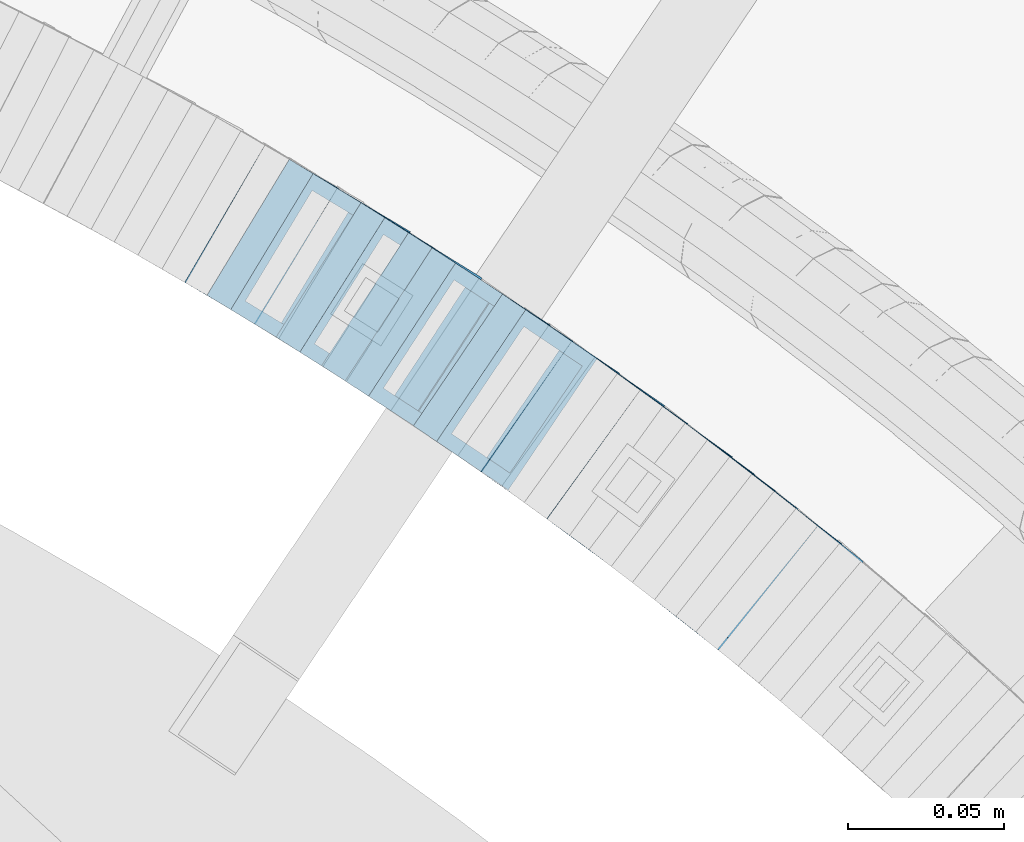
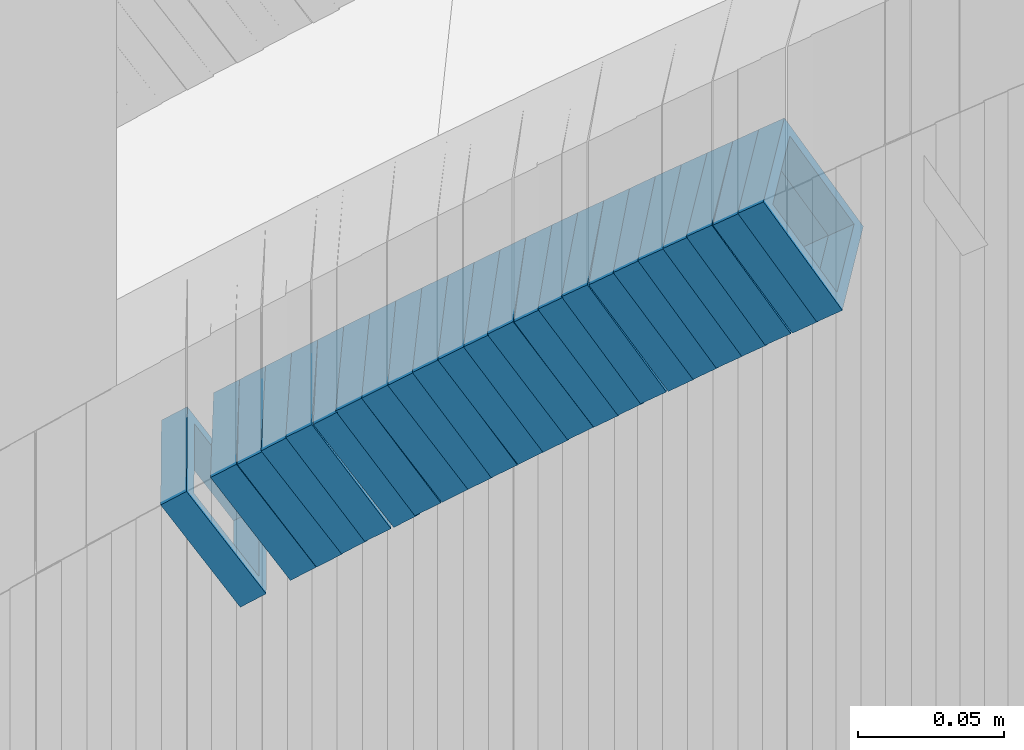
# One storey, part 751 of 975: 23 members.
"""IFC2X3 building model written with IfcOpenShell, lengths in millimetres."""

from ifc_helpers import new_model, si_unit, frame, origin_with_axes, place, context, subcontext, project, spatial, faceted_brep, material, type_object, element, save


model = new_model("IFC2X3")

# Units and contexts
model_context = context("Model", 3, precision=1e-05, world=origin_with_axes())
body_context = subcontext(model_context, "Body", "Model", "MODEL_VIEW")
ifc_project = project(units=[si_unit("LENGTHUNIT", "METRE", prefix="MILLI"), si_unit("AREAUNIT", "SQUARE_METRE"), si_unit("VOLUMEUNIT", "CUBIC_METRE"), si_unit("MASSUNIT", "GRAM", prefix="KILO"), si_unit("TIMEUNIT", "SECOND"), si_unit("PLANEANGLEUNIT", "RADIAN"), si_unit("SOLIDANGLEUNIT", "STERADIAN"), si_unit("THERMODYNAMICTEMPERATUREUNIT", "DEGREE_CELSIUS"), si_unit("LUMINOUSINTENSITYUNIT", "LUMEN")], contexts=[model_context])

# Site, building, storey
site_placement = place(None, origin_with_axes())
site = spatial("IfcSite", under=ifc_project, at=site_placement, CompositionType="ELEMENT")
building_placement = place(site_placement, origin_with_axes())
building = spatial("IfcBuilding", under=site, at=building_placement, Name="Undefined", CompositionType="ELEMENT")
storey_placement = place(building_placement, origin_with_axes())
storey = spatial("IfcBuildingStorey", under=building, at=storey_placement, Name="Undefined", CompositionType="ELEMENT", Elevation=0.0)

# Members
ifc_material = material()
member_type = type_object("IfcMemberType", Name="HSS2X2X.188_TUBES", PredefinedType="NOTDEFINED")
member_1_placement = place(storey_placement, frame((35608.852572287, 4493.42317874416, 1653.40910193398), z_axis=(0.617821551956294, 0.786318338803259, 5.58209194423397e-11), x_axis=(0.662206907099033, -0.520305427077882, 0.539225625080666)))
element("IfcMember", 1, at=member_1_placement, inside=storey, type_object=member_type, material=ifc_material, Name="WALL", ObjectType="HSS2X2X.188_TUBES", context=body_context, shape_type="Brep", body=[
    faceted_brep([(0.0, 20.6374999999753, -20.6375000000298), (0.0, -20.6375000000153, -20.6375000000153), (10.5744976239494, -20.6375000000207, -20.6375000000335), (10.5744976239657, 20.6375000000098, -20.637500000008), (0.0, -20.6374999999825, 20.6375000000335), (10.5744976239639, -20.6375000000244, 20.6374999999753), (0.0, 20.6375000000116, 20.6375000000189), (10.5744976239803, 20.6374999999989, 20.6374999999935), (0.0, 25.3999999999724, -25.4000000000342), (0.0, 25.400000000016, 25.4000000000196), (10.5744976239857, 25.4000000000051, 25.4000000000015), (10.5744976239675, 25.4000000000124, -25.4000000000051), (0.0, -25.399999999976, 25.4000000000378), (10.5744976239639, -25.4000000000287, 25.3999999999724), (0.0, -25.400000000016, -25.4000000000196), (10.5744976239494, -25.4000000000215, -25.4000000000378)], [[[0, 1, 2, 3]], [[1, 4, 5, 2]], [[4, 6, 7, 5]], [[6, 0, 3, 7]], [[8, 9, 10, 11]], [[9, 12, 13, 10]], [[12, 14, 15, 13]], [[14, 8, 11, 15]], [[13, 15, 11, 10], [5, 7, 3, 2]], [[14, 12, 9, 8], [6, 4, 1, 0]]]),
])
member_2_placement = place(storey_placement, frame((35602.0141708895, 4498.83895323166, 1647.66268788927), z_axis=(0.612397742431603, 0.790549811880742, -1.31450178741943e-10), x_axis=(0.664102681131935, -0.514445739102132, 0.542506415107726)))
element("IfcMember", 2, at=member_2_placement, inside=storey, type_object=member_type, material=ifc_material, Name="WALL", ObjectType="HSS2X2X.188_TUBES", context=body_context, shape_type="Brep", body=[
    faceted_brep([(0.0, 20.6374999999753, -20.6375000000298), (0.0, -20.6375000000153, -20.6375000000153), (10.6906501205649, -20.6374999999844, -20.637499999968), (10.690650120574, 20.6375000000098, -20.6374999999716), (0.0, -20.6374999999825, 20.6375000000335), (10.6906501205467, -20.6374999999844, 20.637500000008), (0.0, 20.6375000000116, 20.6375000000189), (10.6906501205558, 20.637500000008, 20.6375000000007), (0.0, 25.3999999999724, -25.4000000000342), (0.0, 25.400000000016, 25.4000000000196), (10.6906501205522, 25.4000000000087, 25.3999999999978), (10.6906501205813, 25.4000000000124, -25.3999999999651), (0.0, -25.399999999976, 25.4000000000378), (10.6906501205431, -25.3999999999833, 25.4000000000051), (0.0, -25.400000000016, -25.4000000000196), (10.6906501205704, -25.3999999999833, -25.3999999999614)], [[[0, 1, 2, 3]], [[1, 4, 5, 2]], [[4, 6, 7, 5]], [[6, 0, 3, 7]], [[8, 9, 10, 11]], [[9, 12, 13, 10]], [[12, 14, 15, 13]], [[14, 8, 11, 15]], [[13, 15, 11, 10], [5, 7, 3, 2]], [[14, 12, 9, 8], [6, 4, 1, 0]]]),
])
member_3_placement = place(storey_placement, frame((35594.752572287, 4504.42317874415, 1641.90910193393), z_axis=(0.617821551956294, 0.786318338803259, 5.58209194423397e-11), x_axis=(0.662206907099033, -0.520305427077882, 0.539225625080666)))
element("IfcMember", 3, at=member_3_placement, inside=storey, type_object=member_type, material=ifc_material, Name="WALL", ObjectType="HSS2X2X.188_TUBES", context=body_context, shape_type="Brep", body=[
    faceted_brep([(0.0, 20.6374999999753, -20.6375000000298), (0.0, -20.6375000000153, -20.6375000000153), (10.5744976239494, -20.6375000000207, -20.6375000000335), (10.5744976239657, 20.6375000000098, -20.637500000008), (0.0, -20.6374999999825, 20.6375000000335), (10.5744976239639, -20.6375000000244, 20.6374999999753), (0.0, 20.6375000000116, 20.6375000000189), (10.5744976239803, 20.6374999999989, 20.6374999999935), (0.0, 25.3999999999724, -25.4000000000342), (0.0, 25.400000000016, 25.4000000000196), (10.5744976239857, 25.4000000000051, 25.4000000000015), (10.5744976239675, 25.4000000000124, -25.4000000000051), (0.0, -25.399999999976, 25.4000000000378), (10.5744976239639, -25.4000000000287, 25.3999999999724), (0.0, -25.400000000016, -25.4000000000196), (10.5744976239494, -25.4000000000215, -25.4000000000378)], [[[0, 1, 2, 3]], [[1, 4, 5, 2]], [[4, 6, 7, 5]], [[6, 0, 3, 7]], [[8, 9, 10, 11]], [[9, 12, 13, 10]], [[12, 14, 15, 13]], [[14, 8, 11, 15]], [[13, 15, 11, 10], [5, 7, 3, 2]], [[14, 12, 9, 8], [6, 4, 1, 0]]]),
])
member_4_placement = place(storey_placement, frame((35588.0851947886, 4509.76105518458, 1636.1965843137), z_axis=(0.60536747118571, 0.795946119300935, -2.19542926060967e-11), x_axis=(0.670707309990836, -0.510115418993068, 0.538455163992679)))
element("IfcMember", 4, at=member_4_placement, inside=storey, type_object=member_type, material=ifc_material, Name="WALL", ObjectType="HSS2X2X.188_TUBES", context=body_context, shape_type="Brep", body=[
    faceted_brep([(0.0, 20.6374999999753, -20.6375000000298), (0.0, -20.6375000000153, -20.6375000000153), (10.5948100501191, -20.6375000000335, -20.6375000000844), (10.5948100501555, 20.6374999999971, -20.6375000000116), (0.0, -20.6374999999825, 20.6375000000335), (10.5948100501446, -20.6375000000098, 20.6374999999571), (0.0, 20.6375000000116, 20.6375000000189), (10.5948100501828, 20.6375000000189, 20.6375000000298), (0.0, 25.3999999999724, -25.4000000000342), (0.0, 25.400000000016, 25.4000000000196), (10.5948100501919, 25.4000000000251, 25.4000000000451), (10.5948100501591, 25.3999999999978, -25.4000000000051), (0.0, -25.399999999976, 25.4000000000378), (10.5948100501482, -25.4000000000106, 25.3999999999578), (0.0, -25.400000000016, -25.4000000000196), (10.5948100501118, -25.4000000000378, -25.400000000096)], [[[0, 1, 2, 3]], [[1, 4, 5, 2]], [[4, 6, 7, 5]], [[6, 0, 3, 7]], [[8, 9, 10, 11]], [[9, 12, 13, 10]], [[12, 14, 15, 13]], [[14, 8, 11, 15]], [[13, 15, 11, 10], [5, 7, 3, 2]], [[14, 12, 9, 8], [6, 4, 1, 0]]]),
])
member_5_placement = place(storey_placement, frame((35581.0078218624, 4515.18335922341, 1630.4415954991), z_axis=(0.599999999847897, 0.800000000114077, 6.1926584749017e-11), x_axis=(0.675855260383057, -0.506891445287378, 0.535052081303328)))
element("IfcMember", 5, at=member_5_placement, inside=storey, type_object=member_type, material=ifc_material, Name="WALL", ObjectType="HSS2X2X.188_TUBES", context=body_context, shape_type="Brep", body=[
    faceted_brep([(0.0, 20.6374999999753, -20.6375000000298), (0.0, -20.6375000000153, -20.6375000000153), (10.648004507897, -20.6374999999862, -20.637499999968), (10.6480045078188, 20.6374999999771, -20.6375000000808), (0.0, -20.6374999999825, 20.6375000000335), (10.6480045079406, -20.6374999999698, 20.6375000001062), (0.0, 20.6375000000116, 20.6375000000189), (10.6480045078679, 20.6374999999935, 20.6375000000007), (0.0, 25.3999999999724, -25.4000000000342), (0.0, 25.400000000016, 25.4000000000196), (10.6480045078661, 25.3999999999905, 25.4000000000015), (10.648004507806, 25.3999999999705, -25.4000000000997), (0.0, -25.399999999976, 25.4000000000378), (10.6480045079552, -25.3999999999633, 25.4000000001288), (0.0, -25.400000000016, -25.4000000000196), (10.6480045078988, -25.3999999999814, -25.3999999999651)], [[[0, 1, 2, 3]], [[1, 4, 5, 2]], [[4, 6, 7, 5]], [[6, 0, 3, 7]], [[8, 9, 10, 11]], [[9, 12, 13, 10]], [[12, 14, 15, 13]], [[14, 8, 11, 15]], [[13, 15, 11, 10], [5, 7, 3, 2]], [[14, 12, 9, 8], [6, 4, 1, 0]]]),
])
member_6_placement = place(storey_placement, frame((35574.2508798489, 4520.30696019008, 1624.79130712751), z_axis=(0.592817428552363, 0.805336883797435, 3.6648793866334e-10), x_axis=(0.675617177995574, -0.497329311996768, 0.544247171996436)))
element("IfcMember", 6, at=member_6_placement, inside=storey, type_object=member_type, material=ifc_material, Name="WALL", ObjectType="HSS2X2X.188_TUBES", context=body_context, shape_type="Brep", body=[
    faceted_brep([(0.0, 20.6374999999753, -20.6375000000298), (0.0, -20.6375000000153, -20.6375000000153), (10.6625512894789, -20.6374999999625, -20.6374999999389), (10.6625512893879, 20.6374999999789, -20.6375000000371), (0.0, -20.6374999999825, 20.6375000000335), (10.6625512894352, -20.6374999999989, 20.6375000000153), (0.0, 20.6375000000116, 20.6375000000189), (10.6625512893443, 20.6374999999443, 20.6374999999134), (0.0, 25.3999999999724, -25.4000000000342), (0.0, 25.400000000016, 25.4000000000196), (10.6625512893297, 25.3999999999342, 25.3999999998996), (10.6625512893916, 25.399999999976, -25.4000000000415), (0.0, -25.399999999976, 25.4000000000378), (10.6625512894389, -25.399999999996, 25.400000000016), (0.0, -25.400000000016, -25.4000000000196), (10.6625512894971, -25.3999999999523, -25.3999999999214)], [[[0, 1, 2, 3]], [[1, 4, 5, 2]], [[4, 6, 7, 5]], [[6, 0, 3, 7]], [[8, 9, 10, 11]], [[9, 12, 13, 10]], [[12, 14, 15, 13]], [[14, 8, 11, 15]], [[13, 15, 11, 10], [5, 7, 3, 2]], [[14, 12, 9, 8], [6, 4, 1, 0]]]),
])
member_7_placement = place(storey_placement, frame((35559.7147513933, 4530.90716585884, 1613.2825958355), z_axis=(0.592817428552363, 0.805336883797435, 3.6648793866334e-10), x_axis=(0.679063997791765, -0.499866553846968, 0.537592331835399)))
element("IfcMember", 7, at=member_7_placement, inside=storey, type_object=member_type, material=ifc_material, Name="WALL", ObjectType="HSS2X2X.188_TUBES", context=body_context, shape_type="Brep", body=[
    faceted_brep([(0.0, 20.6374999999753, -20.6375000000298), (0.0, -20.6375000000153, -20.6375000000153), (10.6004716875832, -20.6375000000153, -20.6375000000553), (10.6004716875814, 20.6374999999898, -20.6375000000444), (0.0, -20.6374999999825, 20.6375000000335), (10.6004716876068, -20.6375000000044, 20.6374999999862), (0.0, 20.6375000000116, 20.6375000000189), (10.6004716876032, 20.6374999999989, 20.6374999999971), (0.0, 25.3999999999724, -25.4000000000342), (0.0, 25.400000000016, 25.4000000000196), (10.600471687605, 25.4000000000015, 25.4000000000051), (10.6004716875814, 25.3999999999869, -25.4000000000487), (0.0, -25.399999999976, 25.4000000000378), (10.6004716876068, -25.4000000000015, 25.3999999999905), (0.0, -25.400000000016, -25.4000000000196), (10.6004716875814, -25.4000000000178, -25.4000000000669)], [[[0, 1, 2, 3]], [[1, 4, 5, 2]], [[4, 6, 7, 5]], [[6, 0, 3, 7]], [[8, 9, 10, 11]], [[9, 12, 13, 10]], [[12, 14, 15, 13]], [[14, 8, 11, 15]], [[13, 15, 11, 10], [5, 7, 3, 2]], [[14, 12, 9, 8], [6, 4, 1, 0]]]),
])
member_8_placement = place(storey_placement, frame((35567.22586322, 4525.53391852304, 1619.02367432846), z_axis=(0.585490553898862, 0.810679228360518, -1.8809009816323e-10), x_axis=(0.682257607152496, -0.492741605110172, 0.540120605120747)))
element("IfcMember", 8, at=member_8_placement, inside=storey, type_object=member_type, material=ifc_material, Name="WALL", ObjectType="HSS2X2X.188_TUBES", context=body_context, shape_type="Brep", body=[
    faceted_brep([(0.0, 20.6374999999753, -20.6375000000298), (0.0, -20.6375000000153, -20.6375000000153), (10.5531985672587, -20.6374999999916, -20.6375000000007), (10.5531985672878, 20.6375000000062, -20.6374999999789), (0.0, -20.6374999999825, 20.6375000000335), (10.5531985672114, -20.6375000000353, 20.6374999999171), (0.0, 20.6375000000116, 20.6375000000189), (10.5531985672333, 20.6374999999607, 20.6374999999316), (0.0, 25.3999999999724, -25.4000000000342), (0.0, 25.400000000016, 25.4000000000196), (10.5531985672314, 25.399999999956, 25.3999999999251), (10.5531985672933, 25.4000000000106, -25.3999999999724), (0.0, -25.399999999976, 25.4000000000378), (10.5531985672023, -25.4000000000397, 25.3999999999069), (0.0, -25.400000000016, -25.4000000000196), (10.5531985672642, -25.3999999999851, -25.3999999999869)], [[[0, 1, 2, 3]], [[1, 4, 5, 2]], [[4, 6, 7, 5]], [[6, 0, 3, 7]], [[8, 9, 10, 11]], [[9, 12, 13, 10]], [[12, 14, 15, 13]], [[14, 8, 11, 15]], [[13, 15, 11, 10], [5, 7, 3, 2]], [[14, 12, 9, 8], [6, 4, 1, 0]]]),
])
member_9_placement = place(storey_placement, frame((35545.863271981, 4541.1234277239, 1601.75033671534), z_axis=(0.567472910754303, 0.823392066733727, -3.24725988321006e-11), x_axis=(0.69533396026842, -0.479216648185229, 0.535595078206988)))
element("IfcMember", 9, at=member_9_placement, inside=storey, type_object=member_type, material=ifc_material, Name="WALL", ObjectType="HSS2X2X.188_TUBES", context=body_context, shape_type="Brep", body=[
    faceted_brep([(0.0, 20.6374999999753, -20.6375000000298), (0.0, -20.6375000000153, -20.6375000000153), (10.6395488625676, -20.6374999999771, -20.6374999999716), (10.6395488625531, 20.6374999999916, -20.6375000000189), (0.0, -20.6374999999825, 20.6375000000335), (10.6395488625731, -20.6374999999844, 20.6375000000153), (0.0, 20.6375000000116, 20.6375000000189), (10.6395488625585, 20.6374999999825, 20.637499999968), (0.0, 25.3999999999724, -25.4000000000342), (0.0, 25.400000000016, 25.4000000000196), (10.6395488625567, 25.3999999999778, 25.3999999999614), (10.6395488625494, 25.3999999999887, -25.4000000000233), (0.0, -25.399999999976, 25.4000000000378), (10.6395488625749, -25.3999999999851, 25.400000000016), (0.0, -25.400000000016, -25.4000000000196), (10.6395488625658, -25.399999999976, -25.3999999999687)], [[[0, 1, 2, 3]], [[1, 4, 5, 2]], [[4, 6, 7, 5]], [[6, 0, 3, 7]], [[8, 9, 10, 11]], [[9, 12, 13, 10]], [[12, 14, 15, 13]], [[14, 8, 11, 15]], [[13, 15, 11, 10], [5, 7, 3, 2]], [[14, 12, 9, 8], [6, 4, 1, 0]]]),
])
member_10_placement = place(storey_placement, frame((35552.9785222053, 4535.9633094844, 1607.57557519237), z_axis=(0.580182279700107, 0.814486661844125, -9.95435129880206e-11), x_axis=(0.683797621876635, -0.487088716912275, 0.543291260902117)))
element("IfcMember", 10, at=member_10_placement, inside=storey, type_object=member_type, material=ifc_material, Name="WALL", ObjectType="HSS2X2X.188_TUBES", context=body_context, shape_type="Brep", body=[
    faceted_brep([(0.0, 20.6374999999753, -20.6375000000298), (0.0, -20.6375000000153, -20.6375000000153), (10.6831643251735, -20.6375000000498, -20.6375000000953), (10.6831643252044, 20.637499999988, -20.6375000000226), (0.0, -20.6374999999825, 20.6375000000335), (10.6831643251935, -20.6375000000135, 20.637499999968), (0.0, 20.6375000000116, 20.6375000000189), (10.6831643252244, 20.6375000000226, 20.6375000000407), (0.0, 25.3999999999724, -25.4000000000342), (0.0, 25.400000000016, 25.4000000000196), (10.6831643252317, 25.4000000000306, 25.4000000000597), (10.6831643252044, 25.3999999999905, -25.4000000000196), (0.0, -25.399999999976, 25.4000000000378), (10.6831643251917, -25.400000000016, 25.3999999999614), (0.0, -25.400000000016, -25.4000000000196), (10.6831643251644, -25.400000000056, -25.4000000001179)], [[[0, 1, 2, 3]], [[1, 4, 5, 2]], [[4, 6, 7, 5]], [[6, 0, 3, 7]], [[8, 9, 10, 11]], [[9, 12, 13, 10]], [[12, 14, 15, 13]], [[14, 8, 11, 15]], [[13, 15, 11, 10], [5, 7, 3, 2]], [[14, 12, 9, 8], [6, 4, 1, 0]]]),
])
member_11_placement = place(storey_placement, frame((35538.5925823969, 4546.09656848729, 1596.11633482363), z_axis=(0.572708439163943, 0.819759137619338, 2.2952235667617e-10), x_axis=(0.686908622877717, -0.479895065914461, 0.545763015902685)))
element("IfcMember", 11, at=member_11_placement, inside=storey, type_object=member_type, material=ifc_material, Name="WALL", ObjectType="HSS2X2X.188_TUBES", context=body_context, shape_type="Brep", body=[
    faceted_brep([(0.0, 20.6374999999753, -20.6375000000298), (0.0, -20.6375000000153, -20.6375000000153), (10.6348483769107, -20.637499999988, -20.6374999999825), (10.6348483768415, 20.6374999999734, -20.6375000001026), (0.0, -20.6374999999825, 20.6375000000335), (10.6348483769852, -20.6374999999589, 20.6375000001462), (0.0, 20.6375000000116, 20.6375000000189), (10.6348483769161, 20.6375000000044, 20.6375000000226), (0.0, 25.3999999999724, -25.4000000000342), (0.0, 25.400000000016, 25.4000000000196), (10.6348483769179, 25.4000000000015, 25.4000000000233), (10.6348483768288, 25.3999999999669, -25.4000000001324), (0.0, -25.399999999976, 25.4000000000378), (10.6348483769998, -25.3999999999505, 25.4000000001688), (0.0, -25.400000000016, -25.4000000000196), (10.6348483769107, -25.3999999999887, -25.3999999999833)], [[[0, 1, 2, 3]], [[1, 4, 5, 2]], [[4, 6, 7, 5]], [[6, 0, 3, 7]], [[8, 9, 10, 11]], [[9, 12, 13, 10]], [[12, 14, 15, 13]], [[14, 8, 11, 15]], [[13, 15, 11, 10], [5, 7, 3, 2]], [[14, 12, 9, 8], [6, 4, 1, 0]]]),
])
member_12_placement = place(storey_placement, frame((35531.478003793, 4551.16084011786, 1590.28918918588), z_axis=(0.559857411141056, 0.828588968783941, -7.58991518523543e-11), x_axis=(0.698455183967467, -0.471929177978196, 0.537999262975142)))
element("IfcMember", 12, at=member_12_placement, inside=storey, type_object=member_type, material=ifc_material, Name="WALL", ObjectType="HSS2X2X.188_TUBES", context=body_context, shape_type="Brep", body=[
    faceted_brep([(0.0, 20.6374999999753, -20.6375000000298), (0.0, -20.6375000000153, -20.6375000000153), (10.5948100501191, -20.6375000000335, -20.6375000000844), (10.5948100501555, 20.6374999999971, -20.6375000000116), (0.0, -20.6374999999825, 20.6375000000335), (10.5948100501446, -20.6375000000098, 20.6374999999571), (0.0, 20.6375000000116, 20.6375000000189), (10.5948100501828, 20.6375000000189, 20.6375000000298), (0.0, 25.3999999999724, -25.4000000000342), (0.0, 25.400000000016, 25.4000000000196), (10.5948100501919, 25.4000000000251, 25.4000000000451), (10.5948100501591, 25.3999999999978, -25.4000000000051), (0.0, -25.399999999976, 25.4000000000378), (10.5948100501482, -25.4000000000106, 25.3999999999578), (0.0, -25.400000000016, -25.4000000000196), (10.5948100501118, -25.4000000000378, -25.400000000096)], [[[0, 1, 2, 3]], [[1, 4, 5, 2]], [[4, 6, 7, 5]], [[6, 0, 3, 7]], [[8, 9, 10, 11]], [[9, 12, 13, 10]], [[12, 14, 15, 13]], [[14, 8, 11, 15]], [[13, 15, 11, 10], [5, 7, 3, 2]], [[14, 12, 9, 8], [6, 4, 1, 0]]]),
])
member_13_placement = place(storey_placement, frame((35524.2180807405, 4556.06619353172, 1584.59803034813), z_axis=(0.559857411141056, 0.828588968783941, -7.58991518523543e-11), x_axis=(0.69490460911618, -0.469530142078386, 0.544654964090974)))
element("IfcMember", 13, at=member_13_placement, inside=storey, type_object=member_type, material=ifc_material, Name="WALL", ObjectType="HSS2X2X.188_TUBES", context=body_context, shape_type="Brep", body=[
    faceted_brep([(0.0, 20.6374999999753, -20.6375000000298), (0.0, -20.6375000000153, -20.6375000000153), (10.648004507897, -20.6374999999862, -20.637499999968), (10.6480045078188, 20.6374999999771, -20.6375000000808), (0.0, -20.6374999999825, 20.6375000000335), (10.6480045079406, -20.6374999999698, 20.6375000001062), (0.0, 20.6375000000116, 20.6375000000189), (10.6480045078679, 20.6374999999935, 20.6375000000007), (0.0, 25.3999999999724, -25.4000000000342), (0.0, 25.400000000016, 25.4000000000196), (10.6480045078661, 25.3999999999905, 25.4000000000015), (10.648004507806, 25.3999999999705, -25.4000000000997), (0.0, -25.399999999976, 25.4000000000378), (10.6480045079552, -25.3999999999633, 25.4000000001288), (0.0, -25.400000000016, -25.4000000000196), (10.6480045078988, -25.3999999999814, -25.3999999999651)], [[[0, 1, 2, 3]], [[1, 4, 5, 2]], [[4, 6, 7, 5]], [[6, 0, 3, 7]], [[8, 9, 10, 11]], [[9, 12, 13, 10]], [[12, 14, 15, 13]], [[14, 8, 11, 15]], [[13, 15, 11, 10], [5, 7, 3, 2]], [[14, 12, 9, 8], [6, 4, 1, 0]]]),
])
member_14_placement = place(storey_placement, frame((35516.6815766083, 4561.19321011805, 1578.73213828487), z_axis=(0.55470019603009, 0.832050294467936, -1.48306526170927e-10), x_axis=(0.703241758862721, -0.468827838908315, 0.534463736895428)))
element("IfcMember", 14, at=member_14_placement, inside=storey, type_object=member_type, material=ifc_material, Name="WALL", ObjectType="HSS2X2X.188_TUBES", context=body_context, shape_type="Brep", body=[
    faceted_brep([(0.0, 20.6374999999753, -20.6375000000298), (0.0, -20.6375000000153, -20.6375000000153), (10.6625512894789, -20.6374999999625, -20.6374999999389), (10.6625512893879, 20.6374999999789, -20.6375000000371), (0.0, -20.6374999999825, 20.6375000000335), (10.6625512894352, -20.6374999999989, 20.6375000000153), (0.0, 20.6375000000116, 20.6375000000189), (10.6625512893443, 20.6374999999443, 20.6374999999134), (0.0, 25.3999999999724, -25.4000000000342), (0.0, 25.400000000016, 25.4000000000196), (10.6625512893297, 25.3999999999342, 25.3999999998996), (10.6625512893916, 25.399999999976, -25.4000000000415), (0.0, -25.399999999976, 25.4000000000378), (10.6625512894389, -25.399999999996, 25.400000000016), (0.0, -25.400000000016, -25.4000000000196), (10.6625512894971, -25.3999999999523, -25.3999999999214)], [[[0, 1, 2, 3]], [[1, 4, 5, 2]], [[4, 6, 7, 5]], [[6, 0, 3, 7]], [[8, 9, 10, 11]], [[9, 12, 13, 10]], [[12, 14, 15, 13]], [[14, 8, 11, 15]], [[13, 15, 11, 10], [5, 7, 3, 2]], [[14, 12, 9, 8], [6, 4, 1, 0]]]),
])
member_15_placement = place(storey_placement, frame((35509.4977033267, 4566.03597071888, 1573.06985948457), z_axis=(0.546948583923614, 0.837166200072574, -6.59422312310197e-11), x_axis=(0.706322413933377, -0.461463976956402, 0.53680503494929)))
element("IfcMember", 15, at=member_15_placement, inside=storey, type_object=member_type, material=ifc_material, Name="WALL", ObjectType="HSS2X2X.188_TUBES", context=body_context, shape_type="Brep", body=[
    faceted_brep([(0.0, 20.6374999999753, -20.6375000000298), (0.0, -20.6375000000153, -20.6375000000153), (10.6216759506497, -20.637499999968, -20.6374999999534), (10.6216759506497, 20.6375000000262, -20.6374999999643), (0.0, -20.6374999999825, 20.6375000000335), (10.6216759506169, -20.6374999999935, 20.637500000008), (0.0, 20.6375000000116, 20.6375000000189), (10.6216759506242, 20.6375000000007, 20.6374999999971), (0.0, 25.3999999999724, -25.4000000000342), (0.0, 25.400000000016, 25.4000000000196), (10.6216759506169, 25.3999999999978, 25.3999999999869), (10.6216759506533, 25.4000000000269, -25.3999999999614), (0.0, -25.399999999976, 25.4000000000378), (10.6216759506242, -25.3999999999942, 25.4000000000051), (0.0, -25.400000000016, -25.4000000000196), (10.6216759506569, -25.3999999999614, -25.3999999999432)], [[[0, 1, 2, 3]], [[1, 4, 5, 2]], [[4, 6, 7, 5]], [[6, 0, 3, 7]], [[8, 9, 10, 11]], [[9, 12, 13, 10]], [[12, 14, 15, 13]], [[14, 8, 11, 15]], [[13, 15, 11, 10], [5, 7, 3, 2]], [[14, 12, 9, 8], [6, 4, 1, 0]]]),
])
member_16_placement = place(storey_placement, frame((35502.1391759918, 4570.84354191101, 1567.3783194684), z_axis=(0.546948583923614, 0.837166200072574, -6.59422312310197e-11), x_axis=(0.702747648925362, -0.459128463951053, 0.543458181942109)))
element("IfcMember", 16, at=member_16_placement, inside=storey, type_object=member_type, material=ifc_material, Name="WALL", ObjectType="HSS2X2X.188_TUBES", context=body_context, shape_type="Brep", body=[
    faceted_brep([(0.0, 20.6374999999753, -20.6375000000298), (0.0, -20.6375000000153, -20.6375000000153), (10.6709887076922, -20.6374999999844, -20.6374999999825), (10.6709887076995, 20.6375000000171, -20.6374999999753), (0.0, -20.6374999999825, 20.6375000000335), (10.6709887076922, -20.6374999999971, 20.6375000000153), (0.0, 20.6375000000116, 20.6375000000189), (10.6709887076941, 20.6375000000025, 20.6375000000189), (0.0, 25.3999999999724, -25.4000000000342), (0.0, 25.400000000016, 25.4000000000196), (10.6709887076959, 25.3999999999996, 25.4000000000233), (10.6709887077013, 25.4000000000178, -25.3999999999724), (0.0, -25.399999999976, 25.4000000000378), (10.6709887076904, -25.3999999999978, 25.400000000016), (0.0, -25.400000000016, -25.4000000000196), (10.6709887076959, -25.3999999999796, -25.3999999999796)], [[[0, 1, 2, 3]], [[1, 4, 5, 2]], [[4, 6, 7, 5]], [[6, 0, 3, 7]], [[8, 9, 10, 11]], [[9, 12, 13, 10]], [[12, 14, 15, 13]], [[14, 8, 11, 15]], [[13, 15, 11, 10], [5, 7, 3, 2]], [[14, 12, 9, 8], [6, 4, 1, 0]]]),
])
member_17_placement = place(storey_placement, frame((35494.4977033267, 4575.83597071888, 1561.56985948453), z_axis=(0.546948583923614, 0.837166200072574, -6.59422312310197e-11), x_axis=(0.706322413933377, -0.461463976956402, 0.53680503494929)))
element("IfcMember", 17, at=member_17_placement, inside=storey, type_object=member_type, material=ifc_material, Name="WALL", ObjectType="HSS2X2X.188_TUBES", context=body_context, shape_type="Brep", body=[
    faceted_brep([(0.0, 20.6374999999753, -20.6375000000298), (0.0, -20.6375000000153, -20.6375000000153), (10.6216759506497, -20.637499999968, -20.6374999999534), (10.6216759506497, 20.6375000000262, -20.6374999999643), (0.0, -20.6374999999825, 20.6375000000335), (10.6216759506169, -20.6374999999935, 20.637500000008), (0.0, 20.6375000000116, 20.6375000000189), (10.6216759506242, 20.6375000000007, 20.6374999999971), (0.0, 25.3999999999724, -25.4000000000342), (0.0, 25.400000000016, 25.4000000000196), (10.6216759506169, 25.3999999999978, 25.3999999999869), (10.6216759506533, 25.4000000000269, -25.3999999999614), (0.0, -25.399999999976, 25.4000000000378), (10.6216759506242, -25.3999999999942, 25.4000000000051), (0.0, -25.400000000016, -25.4000000000196), (10.6216759506569, -25.3999999999614, -25.3999999999432)], [[[0, 1, 2, 3]], [[1, 4, 5, 2]], [[4, 6, 7, 5]], [[6, 0, 3, 7]], [[8, 9, 10, 11]], [[9, 12, 13, 10]], [[12, 14, 15, 13]], [[14, 8, 11, 15]], [[13, 15, 11, 10], [5, 7, 3, 2]], [[14, 12, 9, 8], [6, 4, 1, 0]]]),
])
member_18_placement = place(storey_placement, frame((35479.7127468132, 4585.31859466363, 1550.04919434139), z_axis=(0.533992991185273, 0.845488903158998, 4.54922428616555e-11), x_axis=(0.714032211209431, -0.450967712132132, 0.535524158156923)))
element("IfcMember", 18, at=member_18_placement, inside=storey, type_object=member_type, material=ifc_material, Name="WALL", ObjectType="HSS2X2X.188_TUBES", context=body_context, shape_type="Brep", body=[
    faceted_brep([(0.0, 20.6374999999753, -20.6375000000298), (0.0, -20.6375000000153, -20.6375000000153), (10.6395488625676, -20.6374999999771, -20.6374999999716), (10.6395488625531, 20.6374999999916, -20.6375000000189), (0.0, -20.6374999999825, 20.6375000000335), (10.6395488625731, -20.6374999999844, 20.6375000000153), (0.0, 20.6375000000116, 20.6375000000189), (10.6395488625585, 20.6374999999825, 20.637499999968), (0.0, 25.3999999999724, -25.4000000000342), (0.0, 25.400000000016, 25.4000000000196), (10.6395488625567, 25.3999999999778, 25.3999999999614), (10.6395488625494, 25.3999999999887, -25.4000000000233), (0.0, -25.399999999976, 25.4000000000378), (10.6395488625749, -25.3999999999851, 25.400000000016), (0.0, -25.400000000016, -25.4000000000196), (10.6395488625658, -25.399999999976, -25.3999999999687)], [[[0, 1, 2, 3]], [[1, 4, 5, 2]], [[4, 6, 7, 5]], [[6, 0, 3, 7]], [[8, 9, 10, 11]], [[9, 12, 13, 10]], [[12, 14, 15, 13]], [[14, 8, 11, 15]], [[13, 15, 11, 10], [5, 7, 3, 2]], [[14, 12, 9, 8], [6, 4, 1, 0]]]),
])
for number, where, z_axis, x_axis, name in (
    (19, (35472.5773439401, 4589.881264936, 1544.39446822254), (0.525969302139259, 0.850503552730464, 1.68892938745557e-10), (0.713402774881971, -0.441183294927101, 0.544438959910081), "WALL"),
    (20, (35487.7773439401, 4580.38126493602, 1555.89446822257), (0.525969302139259, 0.850503552730464, 1.68892938745557e-10), (0.713402774881971, -0.441183294927101, 0.544438959910081), "WALL"),
):
    element("IfcMember", number, at=place(storey_placement, frame(where, z_axis=z_axis, x_axis=x_axis)), inside=storey, type_object=member_type, material=ifc_material, Name=name, ObjectType="HSS2X2X.188_TUBES", context=body_context, shape_type="Brep", body=[
        faceted_brep([(0.0, 20.6374999999753, -20.6375000000298), (0.0, -20.6375000000153, -20.6375000000153), (10.648004507897, -20.6374999999862, -20.637499999968), (10.6480045078188, 20.6374999999771, -20.6375000000808), (0.0, -20.6374999999825, 20.6375000000335), (10.6480045079406, -20.6374999999698, 20.6375000001062), (0.0, 20.6375000000116, 20.6375000000189), (10.6480045078679, 20.6374999999935, 20.6375000000007), (0.0, 25.3999999999724, -25.4000000000342), (0.0, 25.400000000016, 25.4000000000196), (10.6480045078661, 25.3999999999905, 25.4000000000015), (10.648004507806, 25.3999999999705, -25.4000000000997), (0.0, -25.399999999976, 25.4000000000378), (10.6480045079552, -25.3999999999633, 25.4000000001288), (0.0, -25.400000000016, -25.4000000000196), (10.6480045078988, -25.3999999999814, -25.3999999999651)], [[[0, 1, 2, 3]], [[1, 4, 5, 2]], [[4, 6, 7, 5]], [[6, 0, 3, 7]], [[8, 9, 10, 11]], [[9, 12, 13, 10]], [[12, 14, 15, 13]], [[14, 8, 11, 15]], [[13, 15, 11, 10], [5, 7, 3, 2]], [[14, 12, 9, 8], [6, 4, 1, 0]]]),
    ])
member_19_placement = place(storey_placement, frame((35465.144367503, 4594.56546657655, 1538.56256360793), z_axis=(0.512855252238565, 0.858475095882995, 1.68283577295369e-10), x_axis=(0.724547451707134, -0.432846529825224, 0.536353308783455)))
element("IfcMember", 21, at=member_19_placement, inside=storey, type_object=member_type, material=ifc_material, Name="WALL", ObjectType="HSS2X2X.188_TUBES", context=body_context, shape_type="Brep", body=[
    faceted_brep([(0.0, 20.6374999999753, -20.6375000000298), (0.0, -20.6375000000153, -20.6375000000153), (10.6348483769107, -20.637499999988, -20.6374999999825), (10.6348483768415, 20.6374999999734, -20.6375000001026), (0.0, -20.6374999999825, 20.6375000000335), (10.6348483769852, -20.6374999999589, 20.6375000001462), (0.0, 20.6375000000116, 20.6375000000189), (10.6348483769161, 20.6375000000044, 20.6375000000226), (0.0, 25.3999999999724, -25.4000000000342), (0.0, 25.400000000016, 25.4000000000196), (10.6348483769179, 25.4000000000015, 25.4000000000233), (10.6348483768288, 25.3999999999669, -25.4000000001324), (0.0, -25.399999999976, 25.4000000000378), (10.6348483769998, -25.3999999999505, 25.4000000001688), (0.0, -25.400000000016, -25.4000000000196), (10.6348483769107, -25.3999999999887, -25.3999999999833)], [[[0, 1, 2, 3]], [[1, 4, 5, 2]], [[4, 6, 7, 5]], [[6, 0, 3, 7]], [[8, 9, 10, 11]], [[9, 12, 13, 10]], [[12, 14, 15, 13]], [[14, 8, 11, 15]], [[13, 15, 11, 10], [5, 7, 3, 2]], [[14, 12, 9, 8], [6, 4, 1, 0]]]),
])
member_20_placement = place(storey_placement, frame((35457.4579282008, 4599.12535851897, 1532.92209378766), z_axis=(0.51780267961722, 0.855500078890251, -1.87630575965159e-10), x_axis=(0.720031514805102, -0.435808547881873, 0.540023635853621)))
element("IfcMember", 22, at=member_20_placement, inside=storey, type_object=member_type, material=ifc_material, Name="WALL", ObjectType="HSS2X2X.188_TUBES", context=body_context, shape_type="Brep", body=[
    faceted_brep([(0.0, 20.6374999999753, -20.6375000000298), (0.0, -20.6375000000153, -20.6375000000153), (10.5550935571373, -20.6374999999935, -20.6374999999753), (10.5550935571373, 20.6375000000025, -20.6374999999862), (0.0, -20.6374999999825, 20.6375000000335), (10.5550935571027, -20.6374999999989, 20.6374999999862), (0.0, 20.6375000000116, 20.6375000000189), (10.5550935571027, 20.6374999999953, 20.6374999999716), (0.0, 25.3999999999724, -25.4000000000342), (0.0, 25.400000000016, 25.4000000000196), (10.5550935570991, 25.3999999999924, 25.3999999999651), (10.5550935571373, 25.3999999999996, -25.3999999999905), (0.0, -25.399999999976, 25.4000000000378), (10.5550935571009, -25.3999999999996, 25.3999999999833), (0.0, -25.400000000016, -25.4000000000196), (10.5550935571428, -25.3999999999905, -25.3999999999724)], [[[0, 1, 2, 3]], [[1, 4, 5, 2]], [[4, 6, 7, 5]], [[6, 0, 3, 7]], [[8, 9, 10, 11]], [[9, 12, 13, 10]], [[12, 14, 15, 13]], [[14, 8, 11, 15]], [[13, 15, 11, 10], [5, 7, 3, 2]], [[14, 12, 9, 8], [6, 4, 1, 0]]]),
])
member_21_placement = place(storey_placement, frame((35442.3692486829, 4608.12612535188, 1521.39775449215), z_axis=(0.504568019426551, 0.863371944049589, 2.19379444388323e-10), x_axis=(0.727484185892149, -0.425153095937059, 0.538527254920278)))
element("IfcMember", 23, at=member_21_placement, inside=storey, type_object=member_type, material=ifc_material, Name="WALL", ObjectType="HSS2X2X.188_TUBES", context=body_context, shape_type="Brep", body=[
    faceted_brep([(0.0, 20.6374999999753, -20.6375000000298), (0.0, -20.6375000000153, -20.6375000000153), (10.5806427026419, -20.6374999999607, -20.6374999999316), (10.5806427026473, 20.6375000000444, -20.6374999999207), (0.0, -20.6374999999825, 20.6375000000335), (10.5806427025509, -20.6375000000207, 20.6374999999643), (0.0, 20.6375000000116, 20.6375000000189), (10.5806427025545, 20.6374999999862, 20.6374999999716), (0.0, 25.3999999999724, -25.4000000000342), (0.0, 25.400000000016, 25.4000000000196), (10.5806427025436, 25.3999999999796, 25.3999999999614), (10.5806427026582, 25.4000000000542, -25.3999999999105), (0.0, -25.399999999976, 25.4000000000378), (10.5806427025418, -25.4000000000287, 25.3999999999542), (0.0, -25.400000000016, -25.4000000000196), (10.5806427026528, -25.3999999999542, -25.3999999999178)], [[[0, 1, 2, 3]], [[1, 4, 5, 2]], [[4, 6, 7, 5]], [[6, 0, 3, 7]], [[8, 9, 10, 11]], [[9, 12, 13, 10]], [[12, 14, 15, 13]], [[14, 8, 11, 15]], [[13, 15, 11, 10], [5, 7, 3, 2]], [[14, 12, 9, 8], [6, 4, 1, 0]]]),
])

save(model, "model.ifc")
